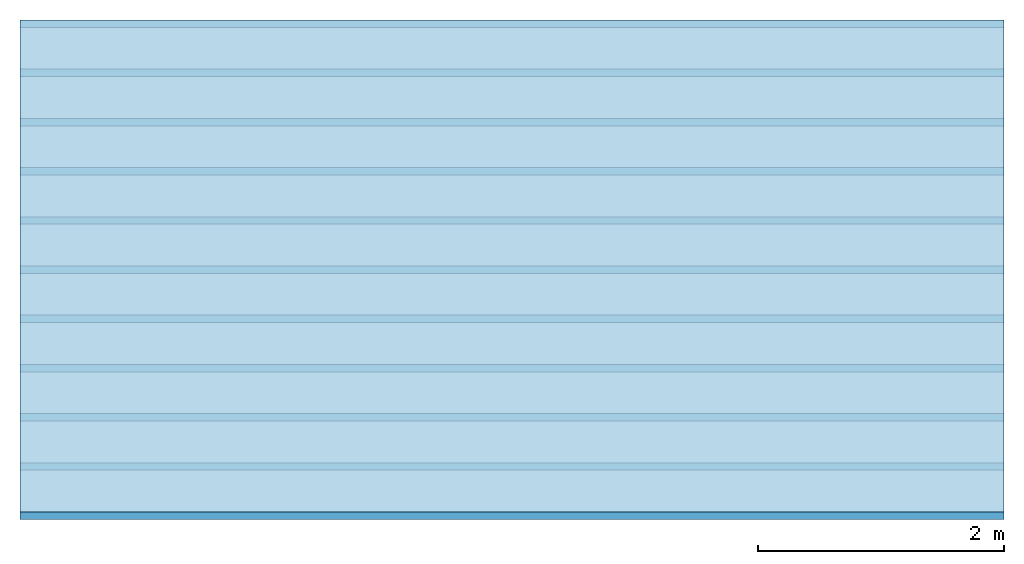
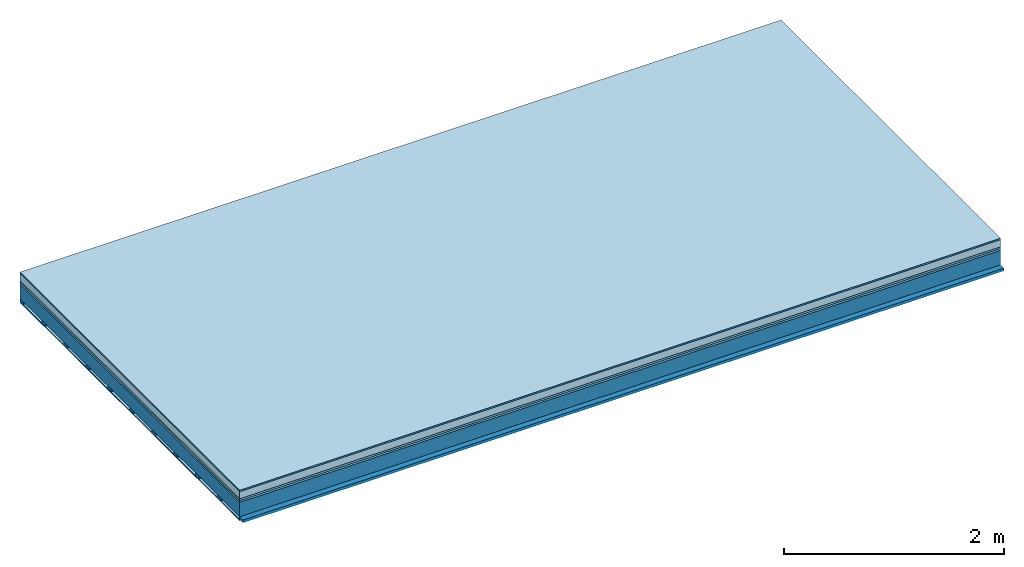
# One storey: 6 plates, 2 members, 1 element without a shape of its own.
"""IFC4 building model written with IfcOpenShell, lengths in metres."""

from ifc_helpers import new_model, si_unit, derived_unit, direction, frame, frame_2d, origin, origin_with_axes, place, context, project, spatial, rectangle, extrude, material, layer, layer_set, type_object, element, aggregate, save


model = new_model("IFC4")

# Units and contexts
plan_context = context("Plan", 3, precision=1e-05, world=origin(), true_north=direction((0.0, 1.0)))
model_context = context("Model", 3, precision=1e-05, world=origin(), true_north=direction((0.0, 1.0)))
ifc_project = project(units=[si_unit("LENGTHUNIT", "METRE"), derived_unit("SOUNDPRESSUREUNIT", [(si_unit("PRESSUREUNIT", "PASCAL", prefix="MICRO"), 0)]), si_unit("ENERGYUNIT", "JOULE", prefix="MEGA"), si_unit("MASSUNIT", "GRAM", prefix="KILO"), derived_unit("THERMALTRANSMITTANCEUNIT", [(si_unit("POWERUNIT", "WATT"), 1), (si_unit("AREAUNIT", "SQUARE_METRE"), -1), (si_unit("THERMODYNAMICTEMPERATUREUNIT", "KELVIN"), -1)]), derived_unit("AREADENSITYUNIT", [(si_unit("MASSUNIT", "GRAM", prefix="KILO"), 1), (si_unit("AREAUNIT", "SQUARE_METRE"), -1)]), derived_unit("USERDEFINED", [(si_unit("ENERGYUNIT", "JOULE", prefix="MEGA"), 1), (si_unit("AREAUNIT", "SQUARE_METRE"), -1)])], contexts=[plan_context, model_context])

# Site, building, storey
site = spatial("IfcSite", under=ifc_project)
building_placement = place(None, origin())
building = spatial("IfcBuilding", under=site, at=building_placement)
storey_placement = place(building_placement, origin())
storey = spatial("IfcBuildingStorey", under=building, at=storey_placement)

# Slab, members, plates
ifc_material_1 = material(Category="11.013")
ifc_layer_1 = layer(ifc_material_1, 0.015, Name="Flooring")
ifc_material_2 = material(Name="Cement screed", Category="04.006")
ifc_layer_2 = layer(ifc_material_2, 0.08, Name="On-material")
ifc_material_3 = material(Name="Wood fiber generic product", Category="10.009")
ifc_layer_3 = layer(ifc_material_3, 0.02, Name="Impact sound insulation")
ifc_material_4 = material(Category="10.004")
ifc_layer_4 = layer(ifc_material_4, 0.02, Name="Additional insulation")
ifc_material_5 = material(Name="no composite action")
ifc_layer_5 = layer(ifc_material_5, 0.0, Name="Bond")
ifc_layer_6 = layer(None, 0.16, Name="Supporting structure")
ifc_material_6 = material(Name="of the art")
ifc_layer_7 = layer(ifc_material_6, 0.0, Name="Bond")
ifc_layer_8 = layer(None, 0.03, Name="Battens / profiles")
ifc_material_7 = material(Name="Plasterboard type A", Category="03.008")
ifc_layer_9 = layer(ifc_material_7, 0.0125, Name="Ceiling covering 1st layer")
ifc_material_8 = material(Category="04.001")
ifc_layer_10 = layer(ifc_material_8, 0.003, Name="Surface / treatment")
ifc_layer_set = layer_set([ifc_layer_1, ifc_layer_2, ifc_layer_3, ifc_layer_4, ifc_layer_5, ifc_layer_6, ifc_layer_7, ifc_layer_8, ifc_layer_9, ifc_layer_10])
slab_type = type_object("IfcSlabType", Name="A2143", PredefinedType="NOTDEFINED", material=ifc_layer_set)
slab_placement = place(None, frame((0.0, 0.0, 0.0), z_axis=(0.0, 0.0, -1.0), x_axis=(1.0, 0.0, 0.0)))
slab = element("IfcSlab", 1, at=slab_placement, inside=storey, type_object=slab_type, material=ifc_layer_set, Name="Slab #1")
ifc_material_9 = material(Name="Solid timber panel")
member_1_placement = place(slab_placement, origin())
member_1 = element("IfcMember", 2, at=member_1_placement, material=ifc_material_9, Name="Supporting structure", context=plan_context, shape_type="SweptSolid", body=[
    extrude(rectangle(XDim=1.0, YDim=0.16, at=frame_2d((0.5, 0.08), x_axis=(1.0, 0.0))), frame((0.0, 4.0, 0.135), z_axis=(0.0, -1.0, 0.0), x_axis=(1.0, 0.0, 0.0)), (0.0, 0.0, 1.0), 4.0),
    extrude(rectangle(XDim=1.0, YDim=0.16, at=frame_2d((0.5, 0.08), x_axis=(1.0, 0.0))), frame((1.0, 4.0, 0.135), z_axis=(0.0, -1.0, 0.0), x_axis=(1.0, 0.0, 0.0)), (0.0, 0.0, 1.0), 4.0),
    extrude(rectangle(XDim=1.0, YDim=0.16, at=frame_2d((0.5, 0.08), x_axis=(1.0, 0.0))), frame((2.0, 4.0, 0.135), z_axis=(0.0, -1.0, 0.0), x_axis=(1.0, 0.0, 0.0)), (0.0, 0.0, 1.0), 4.0),
    extrude(rectangle(XDim=1.0, YDim=0.16, at=frame_2d((0.5, 0.08), x_axis=(1.0, 0.0))), frame((3.0, 4.0, 0.135), z_axis=(0.0, -1.0, 0.0), x_axis=(1.0, 0.0, 0.0)), (0.0, 0.0, 1.0), 4.0),
    extrude(rectangle(XDim=1.0, YDim=0.16, at=frame_2d((0.5, 0.08), x_axis=(1.0, 0.0))), frame((4.0, 4.0, 0.135), z_axis=(0.0, -1.0, 0.0), x_axis=(1.0, 0.0, 0.0)), (0.0, 0.0, 1.0), 4.0),
    extrude(rectangle(XDim=1.0, YDim=0.16, at=frame_2d((0.5, 0.08), x_axis=(1.0, 0.0))), frame((5.0, 4.0, 0.135), z_axis=(0.0, -1.0, 0.0), x_axis=(1.0, 0.0, 0.0)), (0.0, 0.0, 1.0), 4.0),
    extrude(rectangle(XDim=1.0, YDim=0.16, at=frame_2d((0.5, 0.08), x_axis=(1.0, 0.0))), frame((6.0, 4.0, 0.135), z_axis=(0.0, -1.0, 0.0), x_axis=(1.0, 0.0, 0.0)), (0.0, 0.0, 1.0), 4.0),
    extrude(rectangle(XDim=1.0, YDim=0.16, at=frame_2d((0.5, 0.08), x_axis=(1.0, 0.0))), frame((7.0, 4.0, 0.135), z_axis=(0.0, -1.0, 0.0), x_axis=(1.0, 0.0, 0.0)), (0.0, 0.0, 1.0), 4.0),
])
ifc_material_10 = material()
member_2_placement = place(slab_placement, origin())
member_2 = element("IfcMember", 3, at=member_2_placement, material=ifc_material_10, Name="Battens / profiles", context=plan_context, shape_type="SweptSolid", body=[
    extrude(rectangle(XDim=0.06, YDim=0.03, at=frame_2d((0.03, 0.015), x_axis=(1.0, 0.0))), frame((0.0, 0.0, 0.295), z_axis=(1.0, 0.0, 0.0), x_axis=(0.0, 1.0, 0.0)), (0.0, 0.0, 1.0), 8.0),
    extrude(rectangle(XDim=0.06, YDim=0.03, at=frame_2d((0.03, 0.015), x_axis=(1.0, 0.0))), frame((0.0, 0.4, 0.295), z_axis=(1.0, 0.0, 0.0), x_axis=(0.0, 1.0, 0.0)), (0.0, 0.0, 1.0), 8.0),
    extrude(rectangle(XDim=0.06, YDim=0.03, at=frame_2d((0.03, 0.015), x_axis=(1.0, 0.0))), frame((0.0, 0.8, 0.295), z_axis=(1.0, 0.0, 0.0), x_axis=(0.0, 1.0, 0.0)), (0.0, 0.0, 1.0), 8.0),
    extrude(rectangle(XDim=0.06, YDim=0.03, at=frame_2d((0.03, 0.015), x_axis=(1.0, 0.0))), frame((0.0, 1.2, 0.295), z_axis=(1.0, 0.0, 0.0), x_axis=(0.0, 1.0, 0.0)), (0.0, 0.0, 1.0), 8.0),
    extrude(rectangle(XDim=0.06, YDim=0.03, at=frame_2d((0.03, 0.015), x_axis=(1.0, 0.0))), frame((0.0, 1.6, 0.295), z_axis=(1.0, 0.0, 0.0), x_axis=(0.0, 1.0, 0.0)), (0.0, 0.0, 1.0), 8.0),
    extrude(rectangle(XDim=0.06, YDim=0.03, at=frame_2d((0.03, 0.015), x_axis=(1.0, 0.0))), frame((0.0, 2.0, 0.295), z_axis=(1.0, 0.0, 0.0), x_axis=(0.0, 1.0, 0.0)), (0.0, 0.0, 1.0), 8.0),
    extrude(rectangle(XDim=0.06, YDim=0.03, at=frame_2d((0.03, 0.015), x_axis=(1.0, 0.0))), frame((0.0, 2.4, 0.295), z_axis=(1.0, 0.0, 0.0), x_axis=(0.0, 1.0, 0.0)), (0.0, 0.0, 1.0), 8.0),
    extrude(rectangle(XDim=0.06, YDim=0.03, at=frame_2d((0.03, 0.015), x_axis=(1.0, 0.0))), frame((0.0, 2.8, 0.295), z_axis=(1.0, 0.0, 0.0), x_axis=(0.0, 1.0, 0.0)), (0.0, 0.0, 1.0), 8.0),
    extrude(rectangle(XDim=0.06, YDim=0.03, at=frame_2d((0.03, 0.015), x_axis=(1.0, 0.0))), frame((0.0, 3.2, 0.295), z_axis=(1.0, 0.0, 0.0), x_axis=(0.0, 1.0, 0.0)), (0.0, 0.0, 1.0), 8.0),
    extrude(rectangle(XDim=0.06, YDim=0.03, at=frame_2d((0.03, 0.015), x_axis=(1.0, 0.0))), frame((0.0, 3.6, 0.295), z_axis=(1.0, 0.0, 0.0), x_axis=(0.0, 1.0, 0.0)), (0.0, 0.0, 1.0), 8.0),
    extrude(rectangle(XDim=0.06, YDim=0.03, at=frame_2d((0.03, 0.015), x_axis=(1.0, 0.0))), frame((0.0, 4.0, 0.295), z_axis=(1.0, 0.0, 0.0), x_axis=(0.0, 1.0, 0.0)), (0.0, 0.0, 1.0), 8.0),
])
plate_1_placement = place(slab_placement, origin())
plate_1 = element("IfcPlate", 4, at=plate_1_placement, material=ifc_material_1, Name="Flooring", context=plan_context, shape_type="SweptSolid", body=[
    extrude(rectangle(XDim=8.0, YDim=4.0, at=frame_2d((4.0, 2.0), x_axis=(1.0, 0.0))), origin_with_axes(), (0.0, 0.0, 1.0), 0.015),
])
plate_2_placement = place(slab_placement, origin())
plate_2 = element("IfcPlate", 5, at=plate_2_placement, material=ifc_material_2, Name="On-material", context=plan_context, shape_type="SweptSolid", body=[
    extrude(rectangle(XDim=8.0, YDim=4.0, at=frame_2d((4.0, 2.0), x_axis=(1.0, 0.0))), frame((0.0, 0.0, 0.015), z_axis=(0.0, 0.0, 1.0), x_axis=(1.0, 0.0, 0.0)), (0.0, 0.0, 1.0), 0.08),
])
plate_3_placement = place(slab_placement, origin())
plate_3 = element("IfcPlate", 6, at=plate_3_placement, material=ifc_material_3, Name="Impact sound insulation", context=plan_context, shape_type="SweptSolid", body=[
    extrude(rectangle(XDim=8.0, YDim=4.0, at=frame_2d((4.0, 2.0), x_axis=(1.0, 0.0))), frame((0.0, 0.0, 0.095), z_axis=(0.0, 0.0, 1.0), x_axis=(1.0, 0.0, 0.0)), (0.0, 0.0, 1.0), 0.02),
])
plate_4_placement = place(slab_placement, origin())
plate_4 = element("IfcPlate", 7, at=plate_4_placement, material=ifc_material_4, Name="Additional insulation", context=plan_context, shape_type="SweptSolid", body=[
    extrude(rectangle(XDim=8.0, YDim=4.0, at=frame_2d((4.0, 2.0), x_axis=(1.0, 0.0))), frame((0.0, 0.0, 0.115), z_axis=(0.0, 0.0, 1.0), x_axis=(1.0, 0.0, 0.0)), (0.0, 0.0, 1.0), 0.02),
])
plate_5_placement = place(slab_placement, origin())
plate_5 = element("IfcPlate", 8, at=plate_5_placement, material=ifc_material_7, Name="Ceiling covering 1st layer", context=plan_context, shape_type="SweptSolid", body=[
    extrude(rectangle(XDim=8.0, YDim=4.0, at=frame_2d((4.0, 2.0), x_axis=(1.0, 0.0))), frame((0.0, 0.0, 0.325), z_axis=(0.0, 0.0, 1.0), x_axis=(1.0, 0.0, 0.0)), (0.0, 0.0, 1.0), 0.0125),
])
plate_6_placement = place(slab_placement, origin())
plate_6 = element("IfcPlate", 9, at=plate_6_placement, material=ifc_material_8, Name="Surface / treatment", context=plan_context, shape_type="SweptSolid", body=[
    extrude(rectangle(XDim=8.0, YDim=4.0, at=frame_2d((4.0, 2.0), x_axis=(1.0, 0.0))), frame((0.0, 0.0, 0.3375), z_axis=(0.0, 0.0, 1.0), x_axis=(1.0, 0.0, 0.0)), (0.0, 0.0, 1.0), 0.003),
])
aggregate(slab, [plate_1, plate_2, plate_3, plate_4, member_1, member_2, plate_5, plate_6])

save(model, "model.ifc")
